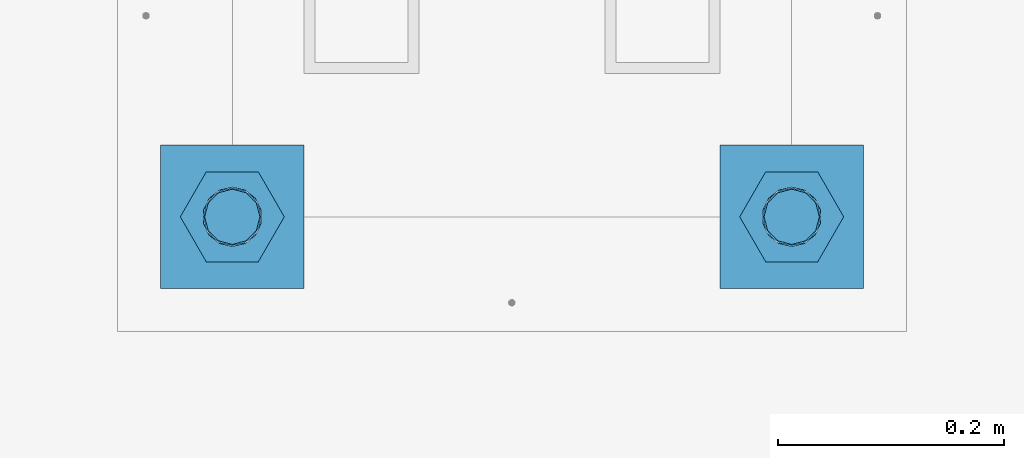
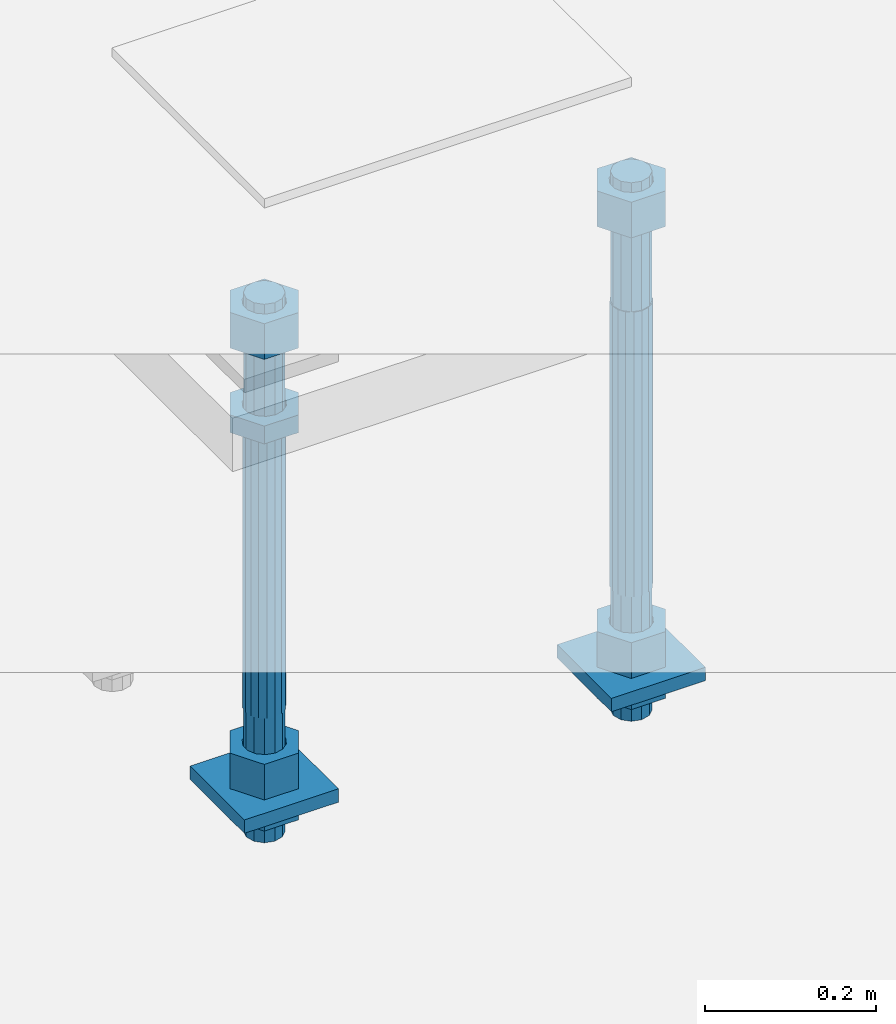
# One storey, part 2692 of 3843: 11 beams, 1 element without a shape of its own.
"""IFC2X3 building model written with IfcOpenShell, lengths in millimetres."""

from ifc_helpers import new_model, si_unit, frame, origin_with_axes, place, context, subcontext, project, spatial, faceted_brep, material, type_object, element, aggregate, save


model = new_model("IFC2X3")

# Units and contexts
model_context = context("Model", 3, precision=1e-05, world=origin_with_axes())
body_context = subcontext(model_context, "Body", "Model", "MODEL_VIEW")
ifc_project = project(units=[si_unit("LENGTHUNIT", "METRE", prefix="MILLI"), si_unit("AREAUNIT", "SQUARE_METRE"), si_unit("VOLUMEUNIT", "CUBIC_METRE"), si_unit("MASSUNIT", "GRAM", prefix="KILO"), si_unit("TIMEUNIT", "SECOND"), si_unit("PLANEANGLEUNIT", "RADIAN"), si_unit("SOLIDANGLEUNIT", "STERADIAN"), si_unit("THERMODYNAMICTEMPERATUREUNIT", "DEGREE_CELSIUS"), si_unit("LUMINOUSINTENSITYUNIT", "LUMEN")], contexts=[model_context])

# Site, building, storey
site_placement = place(None, origin_with_axes())
site = spatial("IfcSite", under=ifc_project, at=site_placement, CompositionType="ELEMENT")
building_placement = place(site_placement, origin_with_axes())
building = spatial("IfcBuilding", under=site, at=building_placement, Name="Undefined", CompositionType="ELEMENT")
storey_placement = place(building_placement, origin_with_axes())
storey = spatial("IfcBuildingStorey", under=building, at=storey_placement, Name="Undefined", CompositionType="ELEMENT", Elevation=0.0)

# Assembly, beams
assembly_placement = place(storey_placement, origin_with_axes())
assembly = element("IfcElementAssembly", 1, at=assembly_placement, inside=storey, Name="TEMPLATE", AssemblyPlace="NOTDEFINED", PredefinedType="RIGID_FRAME")
ifc_material_1 = material(Name="STEEL/A572-50")
beam_type_1 = type_object("IfcBeamType", PredefinedType="NOTDEFINED")
beam_1_placement = place(assembly_placement, frame((105403.65, 35902.8999984741, 29244.925), z_axis=(-1.0, 0.0, 0.0), x_axis=(0.0, -1.0, 0.0)))
beam_1 = element("IfcBeam", 2, at=beam_1_placement, type_object=beam_type_1, material=ifc_material_1, Name="WASHER_PLATE", context=body_context, shape_type="Brep", body=[
    faceted_brep([(0.0, 9.52500000000146, -63.5), (0.0, 9.52500000000146, 63.5), (127.0, 9.52500000000146, 63.5), (127.0, 9.52500000000146, -63.5), (0.0, -9.52500000000146, 63.5), (127.0, -9.52500000000146, 63.5), (0.0, -9.52500000000146, -63.5), (127.0, -9.52500000000146, -63.5)], [[[0, 1, 2, 3]], [[1, 4, 5, 2]], [[4, 6, 7, 5]], [[6, 0, 3, 7]], [[5, 7, 3, 2]], [[6, 4, 1, 0]]]),
])
beam_2_placement = place(assembly_placement, frame((104908.35, 35902.8999984741, 29244.925), z_axis=(-1.0, 0.0, 0.0), x_axis=(0.0, -1.0, 0.0)))
beam_2 = element("IfcBeam", 3, at=beam_2_placement, type_object=beam_type_1, material=ifc_material_1, Name="WASHER_PLATE", context=body_context, shape_type="Brep", body=[
    faceted_brep([(0.0, 9.52500000000146, -63.5), (0.0, 9.52500000000146, 63.5), (127.0, 9.52500000000146, 63.5), (127.0, 9.52500000000146, -63.5), (0.0, -9.52500000000146, 63.5), (127.0, -9.52500000000146, 63.5), (0.0, -9.52500000000146, -63.5), (127.0, -9.52500000000146, -63.5)], [[[0, 1, 2, 3]], [[1, 4, 5, 2]], [[4, 6, 7, 5]], [[6, 0, 3, 7]], [[5, 7, 3, 2]], [[6, 4, 1, 0]]]),
])
ifc_material_2 = material(Name="STEEL/A36")
beam_type_2 = type_object("IfcBeamType", Name="2_HALF_NUT", PredefinedType="NOTDEFINED")
beam_3_placement = place(assembly_placement, frame((105403.65, 35839.3999984741, 29235.4), z_axis=(0.0, -1.0, 0.0), x_axis=(0.0, 0.0, -1.0)))
beam_3 = element("IfcBeam", 4, at=beam_3_placement, type_object=beam_type_2, material=ifc_material_2, Name="NUT", ObjectType="2_HALF_NUT", context=body_context, shape_type="Brep", body=[
    faceted_brep([(0.0, -46.0369987487793, 0.0), (0.0, -23.0184993743896, -39.869213104248), (25.4000000000015, -23.0184993743896, -39.869213104248), (25.4000000000015, -46.0369987487793, 0.0), (0.0, 23.0184993743896, -39.869213104248), (25.4000000000015, 23.0184993743896, -39.869213104248), (0.0, 46.0369987487793, 0.0), (25.4000000000015, 46.0369987487793, 0.0), (0.0, 23.0184993743896, 39.869213104248), (25.4000000000015, 23.0184993743896, 39.869213104248), (0.0, -23.0184993743896, 39.869213104248), (25.4000000000015, -23.0184993743896, 39.869213104248), (0.0, 0.0, 26.1940002441406), (0.0, 11.3650617044477, 23.5999013092805), (25.4000000000015, 11.3650617044477, 23.5999013092805), (25.4000000000015, 0.0, 26.1940002441406), (0.0, 20.4791109456419, 16.3316083006721), (25.4000000000015, 20.4791109456419, 16.3316083006721), (0.0, 25.5370200498292, 5.82867859874386), (25.4000000000015, 25.5370200498292, 5.82867859874386), (0.0, 25.5370200498292, -5.82867859874386), (25.4000000000015, 25.5370200498292, -5.82867859874386), (0.0, 20.4791109456419, -16.3316083006721), (25.4000000000015, 20.4791109456419, -16.3316083006721), (0.0, 11.3650617044477, -23.5999013092805), (25.4000000000015, 11.3650617044477, -23.5999013092805), (0.0, 0.0, -26.1940002441406), (25.4000000000015, 0.0, -26.1940002441406), (0.0, -11.3650617044477, -23.5999013092805), (25.4000000000015, -11.3650617044477, -23.5999013092805), (0.0, -20.4791109456419, -16.3316083006721), (25.4000000000015, -20.4791109456419, -16.3316083006721), (0.0, -25.5370200498292, -5.82867859874386), (25.4000000000015, -25.5370200498292, -5.82867859874386), (0.0, -25.5370200498292, 5.82867859874386), (25.4000000000015, -25.5370200498292, 5.82867859874386), (0.0, -20.4791109456419, 16.3316083006721), (25.4000000000015, -20.4791109456419, 16.3316083006721), (0.0, -11.3650617044477, 23.5999013092805), (25.4000000000015, -11.3650617044477, 23.5999013092805)], [[[0, 1, 2, 3]], [[1, 4, 5, 2]], [[4, 6, 7, 5]], [[6, 8, 9, 7]], [[8, 10, 11, 9]], [[10, 0, 3, 11]], [[12, 13, 14, 15]], [[13, 16, 17, 14]], [[16, 18, 19, 17]], [[18, 20, 21, 19]], [[20, 22, 23, 21]], [[22, 24, 25, 23]], [[24, 26, 27, 25]], [[26, 28, 29, 27]], [[28, 30, 31, 29]], [[30, 32, 33, 31]], [[32, 34, 35, 33]], [[34, 36, 37, 35]], [[36, 38, 39, 37]], [[38, 12, 15, 39]], [[5, 7, 9, 11, 3, 2], [17, 19, 21, 23, 25, 27, 29, 31, 33, 35, 37, 39, 15, 14]], [[10, 8, 6, 4, 1, 0], [38, 36, 34, 32, 30, 28, 26, 24, 22, 20, 18, 16, 13, 12]]]),
])
beam_4_placement = place(assembly_placement, frame((104908.35, 35839.3999984741, 29787.85), z_axis=(0.0, -1.0, 0.0), x_axis=(0.0, 0.0, -1.0)))
beam_4 = element("IfcBeam", 5, at=beam_4_placement, type_object=beam_type_2, material=ifc_material_2, Name="NUT", ObjectType="2_HALF_NUT", context=body_context, shape_type="Brep", body=[
    faceted_brep([(0.0, -46.0369987487793, 0.0), (0.0, -23.0184993743896, -39.869213104248), (25.4000000000015, -23.0184993743896, -39.869213104248), (25.4000000000015, -46.0369987487793, 0.0), (0.0, 23.0184993743896, -39.869213104248), (25.4000000000015, 23.0184993743896, -39.869213104248), (0.0, 46.0369987487793, 0.0), (25.4000000000015, 46.0369987487793, 0.0), (0.0, 23.0184993743896, 39.869213104248), (25.4000000000015, 23.0184993743896, 39.869213104248), (0.0, -23.0184993743896, 39.869213104248), (25.4000000000015, -23.0184993743896, 39.869213104248), (0.0, 0.0, 26.1940002441406), (0.0, 11.3650617044477, 23.5999013092805), (25.4000000000015, 11.3650617044477, 23.5999013092805), (25.4000000000015, 0.0, 26.1940002441406), (0.0, 20.4791109456419, 16.3316083006721), (25.4000000000015, 20.4791109456419, 16.3316083006721), (0.0, 25.5370200498292, 5.82867859874386), (25.4000000000015, 25.5370200498292, 5.82867859874386), (0.0, 25.5370200498292, -5.82867859874386), (25.4000000000015, 25.5370200498292, -5.82867859874386), (0.0, 20.4791109456419, -16.3316083006721), (25.4000000000015, 20.4791109456419, -16.3316083006721), (0.0, 11.3650617044477, -23.5999013092805), (25.4000000000015, 11.3650617044477, -23.5999013092805), (0.0, 0.0, -26.1940002441406), (25.4000000000015, 0.0, -26.1940002441406), (0.0, -11.3650617044477, -23.5999013092805), (25.4000000000015, -11.3650617044477, -23.5999013092805), (0.0, -20.4791109456419, -16.3316083006721), (25.4000000000015, -20.4791109456419, -16.3316083006721), (0.0, -25.5370200498292, -5.82867859874386), (25.4000000000015, -25.5370200498292, -5.82867859874386), (0.0, -25.5370200498292, 5.82867859874386), (25.4000000000015, -25.5370200498292, 5.82867859874386), (0.0, -20.4791109456419, 16.3316083006721), (25.4000000000015, -20.4791109456419, 16.3316083006721), (0.0, -11.3650617044477, 23.5999013092805), (25.4000000000015, -11.3650617044477, 23.5999013092805)], [[[0, 1, 2, 3]], [[1, 4, 5, 2]], [[4, 6, 7, 5]], [[6, 8, 9, 7]], [[8, 10, 11, 9]], [[10, 0, 3, 11]], [[12, 13, 14, 15]], [[13, 16, 17, 14]], [[16, 18, 19, 17]], [[18, 20, 21, 19]], [[20, 22, 23, 21]], [[22, 24, 25, 23]], [[24, 26, 27, 25]], [[26, 28, 29, 27]], [[28, 30, 31, 29]], [[30, 32, 33, 31]], [[32, 34, 35, 33]], [[34, 36, 37, 35]], [[36, 38, 39, 37]], [[38, 12, 15, 39]], [[5, 7, 9, 11, 3, 2], [17, 19, 21, 23, 25, 27, 29, 31, 33, 35, 37, 39, 15, 14]], [[10, 8, 6, 4, 1, 0], [38, 36, 34, 32, 30, 28, 26, 24, 22, 20, 18, 16, 13, 12]]]),
])
beam_5_placement = place(assembly_placement, frame((104908.35, 35839.3999984741, 29235.4), z_axis=(0.0, -1.0, 0.0), x_axis=(0.0, 0.0, -1.0)))
beam_5 = element("IfcBeam", 6, at=beam_5_placement, type_object=beam_type_2, material=ifc_material_2, Name="NUT", ObjectType="2_HALF_NUT", context=body_context, shape_type="Brep", body=[
    faceted_brep([(0.0, -46.0369987487793, 0.0), (0.0, -23.0184993743896, -39.869213104248), (25.4000000000015, -23.0184993743896, -39.869213104248), (25.4000000000015, -46.0369987487793, 0.0), (0.0, 23.0184993743896, -39.869213104248), (25.4000000000015, 23.0184993743896, -39.869213104248), (0.0, 46.0369987487793, 0.0), (25.4000000000015, 46.0369987487793, 0.0), (0.0, 23.0184993743896, 39.869213104248), (25.4000000000015, 23.0184993743896, 39.869213104248), (0.0, -23.0184993743896, 39.869213104248), (25.4000000000015, -23.0184993743896, 39.869213104248), (0.0, 0.0, 26.1940002441406), (0.0, 11.3650617044477, 23.5999013092805), (25.4000000000015, 11.3650617044477, 23.5999013092805), (25.4000000000015, 0.0, 26.1940002441406), (0.0, 20.4791109456419, 16.3316083006721), (25.4000000000015, 20.4791109456419, 16.3316083006721), (0.0, 25.5370200498292, 5.82867859874386), (25.4000000000015, 25.5370200498292, 5.82867859874386), (0.0, 25.5370200498292, -5.82867859874386), (25.4000000000015, 25.5370200498292, -5.82867859874386), (0.0, 20.4791109456419, -16.3316083006721), (25.4000000000015, 20.4791109456419, -16.3316083006721), (0.0, 11.3650617044477, -23.5999013092805), (25.4000000000015, 11.3650617044477, -23.5999013092805), (0.0, 0.0, -26.1940002441406), (25.4000000000015, 0.0, -26.1940002441406), (0.0, -11.3650617044477, -23.5999013092805), (25.4000000000015, -11.3650617044477, -23.5999013092805), (0.0, -20.4791109456419, -16.3316083006721), (25.4000000000015, -20.4791109456419, -16.3316083006721), (0.0, -25.5370200498292, -5.82867859874386), (25.4000000000015, -25.5370200498292, -5.82867859874386), (0.0, -25.5370200498292, 5.82867859874386), (25.4000000000015, -25.5370200498292, 5.82867859874386), (0.0, -20.4791109456419, 16.3316083006721), (25.4000000000015, -20.4791109456419, 16.3316083006721), (0.0, -11.3650617044477, 23.5999013092805), (25.4000000000015, -11.3650617044477, 23.5999013092805)], [[[0, 1, 2, 3]], [[1, 4, 5, 2]], [[4, 6, 7, 5]], [[6, 8, 9, 7]], [[8, 10, 11, 9]], [[10, 0, 3, 11]], [[12, 13, 14, 15]], [[13, 16, 17, 14]], [[16, 18, 19, 17]], [[18, 20, 21, 19]], [[20, 22, 23, 21]], [[22, 24, 25, 23]], [[24, 26, 27, 25]], [[26, 28, 29, 27]], [[28, 30, 31, 29]], [[30, 32, 33, 31]], [[32, 34, 35, 33]], [[34, 36, 37, 35]], [[36, 38, 39, 37]], [[38, 12, 15, 39]], [[5, 7, 9, 11, 3, 2], [17, 19, 21, 23, 25, 27, 29, 31, 33, 35, 37, 39, 15, 14]], [[10, 8, 6, 4, 1, 0], [38, 36, 34, 32, 30, 28, 26, 24, 22, 20, 18, 16, 13, 12]]]),
])
beam_type_3 = type_object("IfcBeamType", Name="2_HEAVY_HEX_NUT", PredefinedType="NOTDEFINED")
beam_6_placement = place(assembly_placement, frame((105403.65, 35839.3999984741, 29933.9), z_axis=(0.0, -1.0, 0.0), x_axis=(0.0, 0.0, -1.0)))
beam_6 = element("IfcBeam", 7, at=beam_6_placement, type_object=beam_type_3, material=ifc_material_2, Name="NUT", ObjectType="2_HEAVY_HEX_NUT", context=body_context, shape_type="Brep", body=[
    faceted_brep([(0.0, -46.0369987487793, 0.0), (0.0, -23.0184993743896, -39.869213104248), (50.7999999999993, -23.0184993743896, -39.869213104248), (50.7999999999993, -46.0369987487793, 0.0), (0.0, 23.0184993743896, -39.869213104248), (50.7999999999993, 23.0184993743896, -39.869213104248), (0.0, 46.0369987487793, 0.0), (50.7999999999993, 46.0369987487793, 0.0), (0.0, 23.0184993743896, 39.869213104248), (50.7999999999993, 23.0184993743896, 39.869213104248), (0.0, -23.0184993743896, 39.869213104248), (50.7999999999993, -23.0184993743896, 39.869213104248), (0.0, 0.0, 26.1940002441406), (0.0, 11.3650617044477, 23.5999013092805), (50.7999999999993, 11.3650617044477, 23.5999013092805), (50.7999999999993, 0.0, 26.1940002441406), (0.0, 20.4791109456419, 16.3316083006721), (50.7999999999993, 20.4791109456419, 16.3316083006721), (0.0, 25.5370200498292, 5.82867859874386), (50.7999999999993, 25.5370200498292, 5.82867859874386), (0.0, 25.5370200498292, -5.82867859874386), (50.7999999999993, 25.5370200498292, -5.82867859874386), (0.0, 20.4791109456419, -16.3316083006721), (50.7999999999993, 20.4791109456419, -16.3316083006721), (0.0, 11.3650617044477, -23.5999013092805), (50.7999999999993, 11.3650617044477, -23.5999013092805), (0.0, 0.0, -26.1940002441406), (50.7999999999993, 0.0, -26.1940002441406), (0.0, -11.3650617044477, -23.5999013092805), (50.7999999999993, -11.3650617044477, -23.5999013092805), (0.0, -20.4791109456419, -16.3316083006721), (50.7999999999993, -20.4791109456419, -16.3316083006721), (0.0, -25.5370200498292, -5.82867859874386), (50.7999999999993, -25.5370200498292, -5.82867859874386), (0.0, -25.5370200498292, 5.82867859874386), (50.7999999999993, -25.5370200498292, 5.82867859874386), (0.0, -20.4791109456419, 16.3316083006721), (50.7999999999993, -20.4791109456419, 16.3316083006721), (0.0, -11.3650617044477, 23.5999013092805), (50.7999999999993, -11.3650617044477, 23.5999013092805)], [[[0, 1, 2, 3]], [[1, 4, 5, 2]], [[4, 6, 7, 5]], [[6, 8, 9, 7]], [[8, 10, 11, 9]], [[10, 0, 3, 11]], [[12, 13, 14, 15]], [[13, 16, 17, 14]], [[16, 18, 19, 17]], [[18, 20, 21, 19]], [[20, 22, 23, 21]], [[22, 24, 25, 23]], [[24, 26, 27, 25]], [[26, 28, 29, 27]], [[28, 30, 31, 29]], [[30, 32, 33, 31]], [[32, 34, 35, 33]], [[34, 36, 37, 35]], [[36, 38, 39, 37]], [[38, 12, 15, 39]], [[5, 7, 9, 11, 3, 2], [17, 19, 21, 23, 25, 27, 29, 31, 33, 35, 37, 39, 15, 14]], [[10, 8, 6, 4, 1, 0], [38, 36, 34, 32, 30, 28, 26, 24, 22, 20, 18, 16, 13, 12]]]),
])
beam_7_placement = place(assembly_placement, frame((105403.65, 35839.3999984741, 29305.25), z_axis=(0.0, -1.0, 0.0), x_axis=(0.0, 0.0, -1.0)))
beam_7 = element("IfcBeam", 8, at=beam_7_placement, type_object=beam_type_3, material=ifc_material_2, Name="NUT", ObjectType="2_HEAVY_HEX_NUT", context=body_context, shape_type="Brep", body=[
    faceted_brep([(0.0, -46.0369987487793, 0.0), (0.0, -23.0184993743896, -39.869213104248), (50.7999999999993, -23.0184993743896, -39.869213104248), (50.7999999999993, -46.0369987487793, 0.0), (0.0, 23.0184993743896, -39.869213104248), (50.7999999999993, 23.0184993743896, -39.869213104248), (0.0, 46.0369987487793, 0.0), (50.7999999999993, 46.0369987487793, 0.0), (0.0, 23.0184993743896, 39.869213104248), (50.7999999999993, 23.0184993743896, 39.869213104248), (0.0, -23.0184993743896, 39.869213104248), (50.7999999999993, -23.0184993743896, 39.869213104248), (0.0, 0.0, 26.1940002441406), (0.0, 11.3650617044477, 23.5999013092805), (50.7999999999993, 11.3650617044477, 23.5999013092805), (50.7999999999993, 0.0, 26.1940002441406), (0.0, 20.4791109456419, 16.3316083006721), (50.7999999999993, 20.4791109456419, 16.3316083006721), (0.0, 25.5370200498292, 5.82867859874386), (50.7999999999993, 25.5370200498292, 5.82867859874386), (0.0, 25.5370200498292, -5.82867859874386), (50.7999999999993, 25.5370200498292, -5.82867859874386), (0.0, 20.4791109456419, -16.3316083006721), (50.7999999999993, 20.4791109456419, -16.3316083006721), (0.0, 11.3650617044477, -23.5999013092805), (50.7999999999993, 11.3650617044477, -23.5999013092805), (0.0, 0.0, -26.1940002441406), (50.7999999999993, 0.0, -26.1940002441406), (0.0, -11.3650617044477, -23.5999013092805), (50.7999999999993, -11.3650617044477, -23.5999013092805), (0.0, -20.4791109456419, -16.3316083006721), (50.7999999999993, -20.4791109456419, -16.3316083006721), (0.0, -25.5370200498292, -5.82867859874386), (50.7999999999993, -25.5370200498292, -5.82867859874386), (0.0, -25.5370200498292, 5.82867859874386), (50.7999999999993, -25.5370200498292, 5.82867859874386), (0.0, -20.4791109456419, 16.3316083006721), (50.7999999999993, -20.4791109456419, 16.3316083006721), (0.0, -11.3650617044477, 23.5999013092805), (50.7999999999993, -11.3650617044477, 23.5999013092805)], [[[0, 1, 2, 3]], [[1, 4, 5, 2]], [[4, 6, 7, 5]], [[6, 8, 9, 7]], [[8, 10, 11, 9]], [[10, 0, 3, 11]], [[12, 13, 14, 15]], [[13, 16, 17, 14]], [[16, 18, 19, 17]], [[18, 20, 21, 19]], [[20, 22, 23, 21]], [[22, 24, 25, 23]], [[24, 26, 27, 25]], [[26, 28, 29, 27]], [[28, 30, 31, 29]], [[30, 32, 33, 31]], [[32, 34, 35, 33]], [[34, 36, 37, 35]], [[36, 38, 39, 37]], [[38, 12, 15, 39]], [[5, 7, 9, 11, 3, 2], [17, 19, 21, 23, 25, 27, 29, 31, 33, 35, 37, 39, 15, 14]], [[10, 8, 6, 4, 1, 0], [38, 36, 34, 32, 30, 28, 26, 24, 22, 20, 18, 16, 13, 12]]]),
])
beam_8_placement = place(assembly_placement, frame((104908.35, 35839.3999984741, 29933.9), z_axis=(0.0, -1.0, 0.0), x_axis=(0.0, 0.0, -1.0)))
beam_8 = element("IfcBeam", 9, at=beam_8_placement, type_object=beam_type_3, material=ifc_material_2, Name="NUT", ObjectType="2_HEAVY_HEX_NUT", context=body_context, shape_type="Brep", body=[
    faceted_brep([(0.0, -46.0369987487793, 0.0), (0.0, -23.0184993743896, -39.869213104248), (50.7999999999993, -23.0184993743896, -39.869213104248), (50.7999999999993, -46.0369987487793, 0.0), (0.0, 23.0184993743896, -39.869213104248), (50.7999999999993, 23.0184993743896, -39.869213104248), (0.0, 46.0369987487793, 0.0), (50.7999999999993, 46.0369987487793, 0.0), (0.0, 23.0184993743896, 39.869213104248), (50.7999999999993, 23.0184993743896, 39.869213104248), (0.0, -23.0184993743896, 39.869213104248), (50.7999999999993, -23.0184993743896, 39.869213104248), (0.0, 0.0, 26.1940002441406), (0.0, 11.3650617044477, 23.5999013092805), (50.7999999999993, 11.3650617044477, 23.5999013092805), (50.7999999999993, 0.0, 26.1940002441406), (0.0, 20.4791109456419, 16.3316083006721), (50.7999999999993, 20.4791109456419, 16.3316083006721), (0.0, 25.5370200498292, 5.82867859874386), (50.7999999999993, 25.5370200498292, 5.82867859874386), (0.0, 25.5370200498292, -5.82867859874386), (50.7999999999993, 25.5370200498292, -5.82867859874386), (0.0, 20.4791109456419, -16.3316083006721), (50.7999999999993, 20.4791109456419, -16.3316083006721), (0.0, 11.3650617044477, -23.5999013092805), (50.7999999999993, 11.3650617044477, -23.5999013092805), (0.0, 0.0, -26.1940002441406), (50.7999999999993, 0.0, -26.1940002441406), (0.0, -11.3650617044477, -23.5999013092805), (50.7999999999993, -11.3650617044477, -23.5999013092805), (0.0, -20.4791109456419, -16.3316083006721), (50.7999999999993, -20.4791109456419, -16.3316083006721), (0.0, -25.5370200498292, -5.82867859874386), (50.7999999999993, -25.5370200498292, -5.82867859874386), (0.0, -25.5370200498292, 5.82867859874386), (50.7999999999993, -25.5370200498292, 5.82867859874386), (0.0, -20.4791109456419, 16.3316083006721), (50.7999999999993, -20.4791109456419, 16.3316083006721), (0.0, -11.3650617044477, 23.5999013092805), (50.7999999999993, -11.3650617044477, 23.5999013092805)], [[[0, 1, 2, 3]], [[1, 4, 5, 2]], [[4, 6, 7, 5]], [[6, 8, 9, 7]], [[8, 10, 11, 9]], [[10, 0, 3, 11]], [[12, 13, 14, 15]], [[13, 16, 17, 14]], [[16, 18, 19, 17]], [[18, 20, 21, 19]], [[20, 22, 23, 21]], [[22, 24, 25, 23]], [[24, 26, 27, 25]], [[26, 28, 29, 27]], [[28, 30, 31, 29]], [[30, 32, 33, 31]], [[32, 34, 35, 33]], [[34, 36, 37, 35]], [[36, 38, 39, 37]], [[38, 12, 15, 39]], [[5, 7, 9, 11, 3, 2], [17, 19, 21, 23, 25, 27, 29, 31, 33, 35, 37, 39, 15, 14]], [[10, 8, 6, 4, 1, 0], [38, 36, 34, 32, 30, 28, 26, 24, 22, 20, 18, 16, 13, 12]]]),
])
beam_9_placement = place(assembly_placement, frame((104908.35, 35839.3999984741, 29305.25), z_axis=(0.0, -1.0, 0.0), x_axis=(0.0, 0.0, -1.0)))
beam_9 = element("IfcBeam", 10, at=beam_9_placement, type_object=beam_type_3, material=ifc_material_2, Name="NUT", ObjectType="2_HEAVY_HEX_NUT", context=body_context, shape_type="Brep", body=[
    faceted_brep([(0.0, -46.0369987487793, 0.0), (0.0, -23.0184993743896, -39.869213104248), (50.7999999999993, -23.0184993743896, -39.869213104248), (50.7999999999993, -46.0369987487793, 0.0), (0.0, 23.0184993743896, -39.869213104248), (50.7999999999993, 23.0184993743896, -39.869213104248), (0.0, 46.0369987487793, 0.0), (50.7999999999993, 46.0369987487793, 0.0), (0.0, 23.0184993743896, 39.869213104248), (50.7999999999993, 23.0184993743896, 39.869213104248), (0.0, -23.0184993743896, 39.869213104248), (50.7999999999993, -23.0184993743896, 39.869213104248), (0.0, 0.0, 26.1940002441406), (0.0, 11.3650617044477, 23.5999013092805), (50.7999999999993, 11.3650617044477, 23.5999013092805), (50.7999999999993, 0.0, 26.1940002441406), (0.0, 20.4791109456419, 16.3316083006721), (50.7999999999993, 20.4791109456419, 16.3316083006721), (0.0, 25.5370200498292, 5.82867859874386), (50.7999999999993, 25.5370200498292, 5.82867859874386), (0.0, 25.5370200498292, -5.82867859874386), (50.7999999999993, 25.5370200498292, -5.82867859874386), (0.0, 20.4791109456419, -16.3316083006721), (50.7999999999993, 20.4791109456419, -16.3316083006721), (0.0, 11.3650617044477, -23.5999013092805), (50.7999999999993, 11.3650617044477, -23.5999013092805), (0.0, 0.0, -26.1940002441406), (50.7999999999993, 0.0, -26.1940002441406), (0.0, -11.3650617044477, -23.5999013092805), (50.7999999999993, -11.3650617044477, -23.5999013092805), (0.0, -20.4791109456419, -16.3316083006721), (50.7999999999993, -20.4791109456419, -16.3316083006721), (0.0, -25.5370200498292, -5.82867859874386), (50.7999999999993, -25.5370200498292, -5.82867859874386), (0.0, -25.5370200498292, 5.82867859874386), (50.7999999999993, -25.5370200498292, 5.82867859874386), (0.0, -20.4791109456419, 16.3316083006721), (50.7999999999993, -20.4791109456419, 16.3316083006721), (0.0, -11.3650617044477, 23.5999013092805), (50.7999999999993, -11.3650617044477, 23.5999013092805)], [[[0, 1, 2, 3]], [[1, 4, 5, 2]], [[4, 6, 7, 5]], [[6, 8, 9, 7]], [[8, 10, 11, 9]], [[10, 0, 3, 11]], [[12, 13, 14, 15]], [[13, 16, 17, 14]], [[16, 18, 19, 17]], [[18, 20, 21, 19]], [[20, 22, 23, 21]], [[22, 24, 25, 23]], [[24, 26, 27, 25]], [[26, 28, 29, 27]], [[28, 30, 31, 29]], [[30, 32, 33, 31]], [[32, 34, 35, 33]], [[34, 36, 37, 35]], [[36, 38, 39, 37]], [[38, 12, 15, 39]], [[5, 7, 9, 11, 3, 2], [17, 19, 21, 23, 25, 27, 29, 31, 33, 35, 37, 39, 15, 14]], [[10, 8, 6, 4, 1, 0], [38, 36, 34, 32, 30, 28, 26, 24, 22, 20, 18, 16, 13, 12]]]),
])
ifc_material_3 = material()
beam_type_4 = type_object("IfcBeamType", PredefinedType="NOTDEFINED")
beam_10_placement = place(assembly_placement, frame((105403.65, 35839.3999984741, 29762.45), z_axis=(0.0, -1.0, 0.0), x_axis=(0.0, 0.0, -1.0)))
beam_10 = element("IfcBeam", 11, at=beam_10_placement, type_object=beam_type_4, material=ifc_material_3, Name="ANCHOR_ROD", context=body_context, shape_type="Brep", body=[
    faceted_brep([(-184.150000000001, -21.217622392709, 12.25), (-184.150000000001, -12.2499999999854, 21.2176223927163), (-184.150000000001, 1.45519152283669e-11, 24.5), (-184.150000000001, 12.2500000000146, 21.2176223927163), (-184.150000000001, 21.2176223927381, 12.25), (-184.150000000001, 24.5000000000146, 0.0), (-184.150000000001, 21.2176223927381, -12.25), (-184.150000000001, 12.2500000000146, -21.2176223927163), (-184.150000000001, 1.45519152283669e-11, -24.5), (-184.150000000001, -12.2499999999854, -21.2176223927163), (-184.150000000001, -21.217622392709, -12.25), (-184.150000000001, -24.4999999999854, 0.0), (0.0, 24.5000000000146, 0.0), (0.0, 21.2176223927381, -12.25), (0.0, 12.2500000000146, -21.2176223927163), (0.0, 1.45519152283669e-11, -24.5), (0.0, -12.2499999999854, -21.2176223927163), (0.0, -21.217622392709, -12.25), (0.0, -24.4999999999854, 0.0), (0.0, -21.217622392709, 12.25), (0.0, -12.2499999999854, 21.2176223927163), (0.0, 1.45519152283669e-11, 24.5), (0.0, 12.2500000000146, 21.2176223927163), (0.0, 21.2176223927381, 12.25), (0.0, -23.4665401257807, 9.72015918207035), (0.0, -17.9605122421344, 17.9605122421417), (0.0, -9.72015918207762, 23.466540125788), (0.0, 0.0, 25.4000000000015), (0.0, 9.72015918207762, 23.466540125788), (0.0, 17.9605122421344, 17.9605122421417), (0.0, 23.4665401257807, 9.72015918207035), (0.0, 25.3999996185303, 0.0), (0.0, 23.4665401257807, -9.72015918207035), (0.0, 17.9605122421344, -17.9605122421417), (0.0, 9.72015918207762, -23.466540125788), (0.0, 0.0, -25.4000000000015), (0.0, -9.72015918207762, -23.466540125788), (0.0, -17.9605122421344, -17.9605122421417), (0.0, -23.4665401257807, -9.72015918207035), (0.0, -25.3999996185303, 0.0), (406.399999999998, -25.3999999999942, 0.0), (406.399999999998, -23.4665401257807, 9.72015918207035), (406.399999999998, -17.9605122421344, 17.9605122421417), (406.399999999998, -9.72015918207762, 23.466540125788), (406.399999999998, 0.0, 25.4000000000015), (406.399999999998, 9.72015918207762, 23.466540125788), (406.399999999998, 17.9605122421344, 17.9605122421417), (406.399999999998, 23.4665401257807, 9.72015918207035), (406.399999999998, 25.3999999999942, 0.0), (406.399999999998, 23.4665401257807, -9.72015918207035), (406.399999999998, 17.9605122421344, -17.9605122421417), (406.399999999998, 9.72015918207762, -23.466540125788), (406.399999999998, 0.0, -25.4000000000015), (406.399999999998, -9.72015918207762, -23.466540125788), (406.399999999998, -17.9605122421344, -17.9605122421417), (406.399999999998, -23.4665401257807, -9.72015918207035), (406.399999999998, -12.2499999999854, 21.2176223927163), (406.399999999998, 1.45519152283669e-11, 24.5), (406.399999999998, 12.2500000000146, 21.2176223927163), (406.399999999998, 21.2176223927381, 12.25), (406.399999999998, 24.5000000000146, 0.0), (406.399999999998, 21.2176223927381, -12.25), (406.399999999998, 12.2500000000146, -21.2176223927163), (406.399999999998, 1.45519152283669e-11, -24.5), (406.399999999998, -12.2499999999854, -21.2176223927163), (406.399999999998, -21.217622392709, -12.25), (406.399999999998, -24.4999999999854, 0.0), (406.399999999998, -21.217622392709, 12.25), (584.200000000001, -12.2499999999854, -21.2176223927163), (584.200000000001, 1.45519152283669e-11, -24.5), (584.200000000001, 12.2500000000146, -21.2176223927163), (584.200000000001, 21.2176223927381, -12.25), (584.200000000001, 24.5000000000146, 0.0), (584.200000000001, 21.2176223927381, 12.25), (584.200000000001, 12.2500000000146, 21.2176223927163), (584.200000000001, 1.45519152283669e-11, 24.5), (584.200000000001, -12.2499999999854, 21.2176223927163), (584.200000000001, -21.217622392709, 12.25), (584.200000000001, -24.4999999999854, 0.0), (584.200000000001, -21.217622392709, -12.25)], [[[0, 1, 2, 3, 4, 5, 6, 7, 8, 9, 10, 11]], [[6, 5, 12, 13]], [[7, 6, 13, 14]], [[8, 7, 14, 15]], [[9, 8, 15, 16]], [[10, 9, 16, 17]], [[11, 10, 17, 18]], [[0, 11, 18, 19]], [[1, 0, 19, 20]], [[2, 1, 20, 21]], [[3, 2, 21, 22]], [[4, 3, 22, 23]], [[5, 4, 23, 12]], [[24, 25, 26, 27, 28, 29, 30, 31, 32, 33, 34, 35, 36, 37, 38, 39], [22, 21, 20, 19, 18, 17, 16, 15, 14, 13, 12, 23]], [[24, 39, 40, 41]], [[25, 24, 41, 42]], [[26, 25, 42, 43]], [[27, 26, 43, 44]], [[28, 27, 44, 45]], [[29, 28, 45, 46]], [[30, 29, 46, 47]], [[31, 30, 47, 48]], [[32, 31, 48, 49]], [[33, 32, 49, 50]], [[34, 33, 50, 51]], [[35, 34, 51, 52]], [[36, 35, 52, 53]], [[37, 36, 53, 54]], [[38, 37, 54, 55]], [[39, 38, 55, 40]], [[54, 53, 52, 51, 50, 49, 48, 47, 46, 45, 44, 43, 42, 41, 40, 55], [56, 57, 58, 59, 60, 61, 62, 63, 64, 65, 66, 67]], [[68, 69, 70, 71, 72, 73, 74, 75, 76, 77, 78, 79]], [[76, 75, 57, 56]], [[77, 76, 56, 67]], [[78, 77, 67, 66]], [[79, 78, 66, 65]], [[68, 79, 65, 64]], [[69, 68, 64, 63]], [[70, 69, 63, 62]], [[71, 70, 62, 61]], [[72, 71, 61, 60]], [[73, 72, 60, 59]], [[74, 73, 59, 58]], [[75, 74, 58, 57]]]),
])
beam_11_placement = place(assembly_placement, frame((104908.35, 35839.3999984741, 29762.45), z_axis=(0.0, -1.0, 0.0), x_axis=(0.0, 0.0, -1.0)))
beam_11 = element("IfcBeam", 12, at=beam_11_placement, type_object=beam_type_4, material=ifc_material_3, Name="ANCHOR_ROD", context=body_context, shape_type="Brep", body=[
    faceted_brep([(-184.150000000001, -21.217622392709, 12.25), (-184.150000000001, -12.2499999999854, 21.2176223927163), (-184.150000000001, 1.45519152283669e-11, 24.5), (-184.150000000001, 12.2500000000146, 21.2176223927163), (-184.150000000001, 21.2176223927381, 12.25), (-184.150000000001, 24.5000000000146, 0.0), (-184.150000000001, 21.2176223927381, -12.25), (-184.150000000001, 12.2500000000146, -21.2176223927163), (-184.150000000001, 1.45519152283669e-11, -24.5), (-184.150000000001, -12.2499999999854, -21.2176223927163), (-184.150000000001, -21.217622392709, -12.25), (-184.150000000001, -24.4999999999854, 0.0), (0.0, 24.5000000000146, 0.0), (0.0, 21.2176223927381, -12.25), (0.0, 12.2500000000146, -21.2176223927163), (0.0, 1.45519152283669e-11, -24.5), (0.0, -12.2499999999854, -21.2176223927163), (0.0, -21.217622392709, -12.25), (0.0, -24.4999999999854, 0.0), (0.0, -21.217622392709, 12.25), (0.0, -12.2499999999854, 21.2176223927163), (0.0, 1.45519152283669e-11, 24.5), (0.0, 12.2500000000146, 21.2176223927163), (0.0, 21.2176223927381, 12.25), (0.0, -23.4665401257807, 9.72015918207035), (0.0, -17.9605122421344, 17.9605122421417), (0.0, -9.72015918207762, 23.466540125788), (0.0, 0.0, 25.4000000000015), (0.0, 9.72015918207762, 23.466540125788), (0.0, 17.9605122421344, 17.9605122421417), (0.0, 23.4665401257807, 9.72015918207035), (0.0, 25.3999996185303, 0.0), (0.0, 23.4665401257807, -9.72015918207035), (0.0, 17.9605122421344, -17.9605122421417), (0.0, 9.72015918207762, -23.466540125788), (0.0, 0.0, -25.4000000000015), (0.0, -9.72015918207762, -23.466540125788), (0.0, -17.9605122421344, -17.9605122421417), (0.0, -23.4665401257807, -9.72015918207035), (0.0, -25.3999996185303, 0.0), (406.399999999998, -25.3999999999942, 0.0), (406.399999999998, -23.4665401257807, 9.72015918207035), (406.399999999998, -17.9605122421344, 17.9605122421417), (406.399999999998, -9.72015918207762, 23.466540125788), (406.399999999998, 0.0, 25.4000000000015), (406.399999999998, 9.72015918207762, 23.466540125788), (406.399999999998, 17.9605122421344, 17.9605122421417), (406.399999999998, 23.4665401257807, 9.72015918207035), (406.399999999998, 25.3999999999942, 0.0), (406.399999999998, 23.4665401257807, -9.72015918207035), (406.399999999998, 17.9605122421344, -17.9605122421417), (406.399999999998, 9.72015918207762, -23.466540125788), (406.399999999998, 0.0, -25.4000000000015), (406.399999999998, -9.72015918207762, -23.466540125788), (406.399999999998, -17.9605122421344, -17.9605122421417), (406.399999999998, -23.4665401257807, -9.72015918207035), (406.399999999998, -12.2499999999854, 21.2176223927163), (406.399999999998, 1.45519152283669e-11, 24.5), (406.399999999998, 12.2500000000146, 21.2176223927163), (406.399999999998, 21.2176223927381, 12.25), (406.399999999998, 24.5000000000146, 0.0), (406.399999999998, 21.2176223927381, -12.25), (406.399999999998, 12.2500000000146, -21.2176223927163), (406.399999999998, 1.45519152283669e-11, -24.5), (406.399999999998, -12.2499999999854, -21.2176223927163), (406.399999999998, -21.217622392709, -12.25), (406.399999999998, -24.4999999999854, 0.0), (406.399999999998, -21.217622392709, 12.25), (584.200000000001, -12.2499999999854, -21.2176223927163), (584.200000000001, 1.45519152283669e-11, -24.5), (584.200000000001, 12.2500000000146, -21.2176223927163), (584.200000000001, 21.2176223927381, -12.25), (584.200000000001, 24.5000000000146, 0.0), (584.200000000001, 21.2176223927381, 12.25), (584.200000000001, 12.2500000000146, 21.2176223927163), (584.200000000001, 1.45519152283669e-11, 24.5), (584.200000000001, -12.2499999999854, 21.2176223927163), (584.200000000001, -21.217622392709, 12.25), (584.200000000001, -24.4999999999854, 0.0), (584.200000000001, -21.217622392709, -12.25)], [[[0, 1, 2, 3, 4, 5, 6, 7, 8, 9, 10, 11]], [[6, 5, 12, 13]], [[7, 6, 13, 14]], [[8, 7, 14, 15]], [[9, 8, 15, 16]], [[10, 9, 16, 17]], [[11, 10, 17, 18]], [[0, 11, 18, 19]], [[1, 0, 19, 20]], [[2, 1, 20, 21]], [[3, 2, 21, 22]], [[4, 3, 22, 23]], [[5, 4, 23, 12]], [[24, 25, 26, 27, 28, 29, 30, 31, 32, 33, 34, 35, 36, 37, 38, 39], [22, 21, 20, 19, 18, 17, 16, 15, 14, 13, 12, 23]], [[24, 39, 40, 41]], [[25, 24, 41, 42]], [[26, 25, 42, 43]], [[27, 26, 43, 44]], [[28, 27, 44, 45]], [[29, 28, 45, 46]], [[30, 29, 46, 47]], [[31, 30, 47, 48]], [[32, 31, 48, 49]], [[33, 32, 49, 50]], [[34, 33, 50, 51]], [[35, 34, 51, 52]], [[36, 35, 52, 53]], [[37, 36, 53, 54]], [[38, 37, 54, 55]], [[39, 38, 55, 40]], [[54, 53, 52, 51, 50, 49, 48, 47, 46, 45, 44, 43, 42, 41, 40, 55], [56, 57, 58, 59, 60, 61, 62, 63, 64, 65, 66, 67]], [[68, 69, 70, 71, 72, 73, 74, 75, 76, 77, 78, 79]], [[76, 75, 57, 56]], [[77, 76, 56, 67]], [[78, 77, 67, 66]], [[79, 78, 66, 65]], [[68, 79, 65, 64]], [[69, 68, 64, 63]], [[70, 69, 63, 62]], [[71, 70, 62, 61]], [[72, 71, 61, 60]], [[73, 72, 60, 59]], [[74, 73, 59, 58]], [[75, 74, 58, 57]]]),
])
aggregate(assembly, [beam_6, beam_7, beam_3, beam_1, beam_10, beam_4, beam_8, beam_9, beam_5, beam_2, beam_11])

save(model, "model.ifc")
